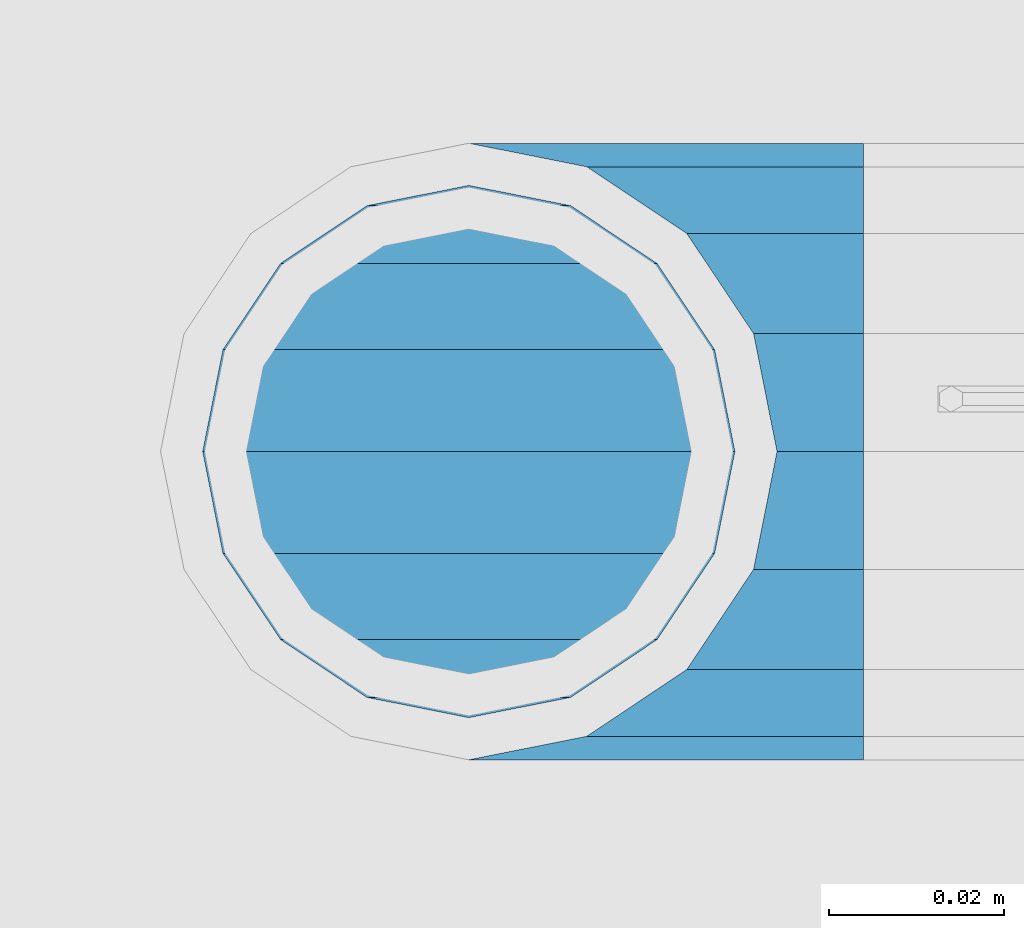
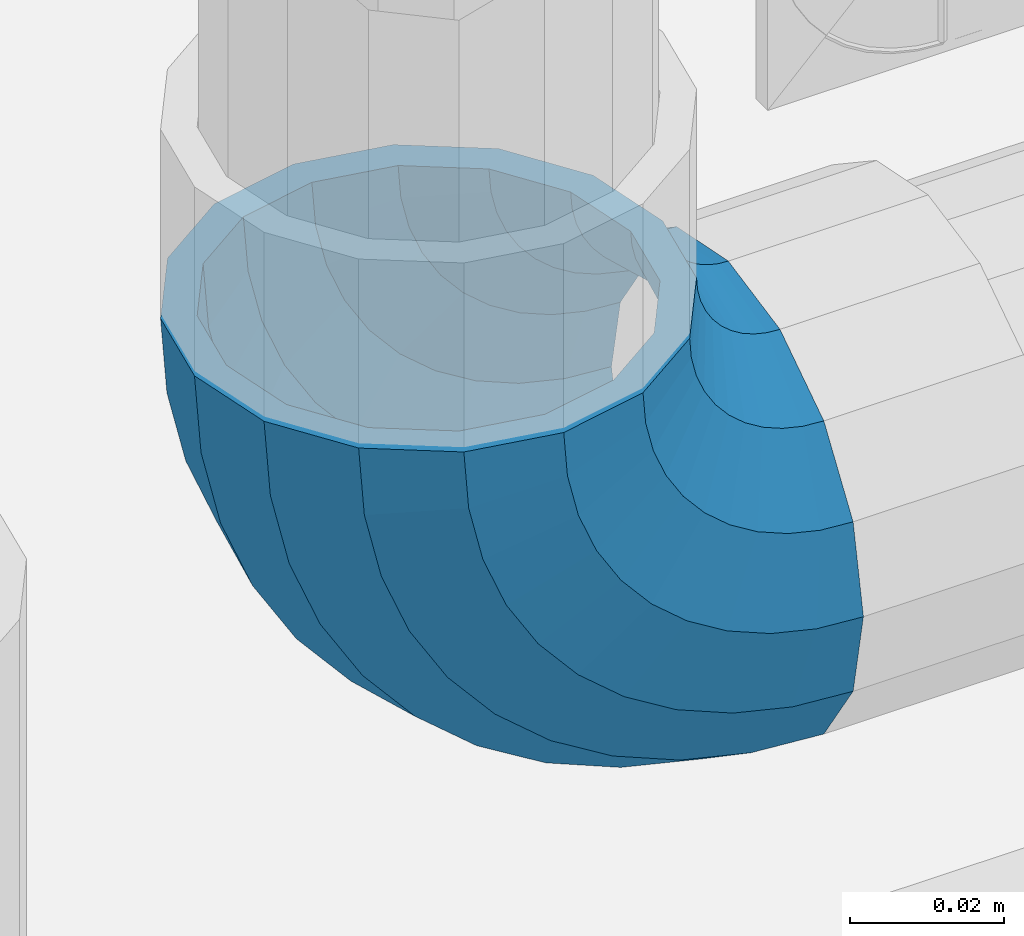
# One storey, part 136 of 208: 1 member.
"""IFC2X3 building model written with IfcOpenShell, lengths in millimetres."""

from ifc_helpers import new_model, si_unit, frame, origin_with_axes, place, context, subcontext, project, spatial, faceted_brep, material, type_object, element, save


model = new_model("IFC2X3")

# Units and contexts
model_context = context("Model", 3, precision=1e-05, world=origin_with_axes())
body_context = subcontext(model_context, "Body", "Model", "MODEL_VIEW")
ifc_project = project(units=[si_unit("LENGTHUNIT", "METRE", prefix="MILLI"), si_unit("AREAUNIT", "SQUARE_METRE"), si_unit("VOLUMEUNIT", "CUBIC_METRE"), si_unit("MASSUNIT", "GRAM", prefix="KILO"), si_unit("TIMEUNIT", "SECOND"), si_unit("PLANEANGLEUNIT", "RADIAN"), si_unit("SOLIDANGLEUNIT", "STERADIAN"), si_unit("THERMODYNAMICTEMPERATUREUNIT", "DEGREE_CELSIUS"), si_unit("LUMINOUSINTENSITYUNIT", "LUMEN")], contexts=[model_context])

# Site, building, storey
site_placement = place(None, origin_with_axes())
site = spatial("IfcSite", under=ifc_project, at=site_placement, CompositionType="ELEMENT")
building_placement = place(site_placement, origin_with_axes())
building = spatial("IfcBuilding", under=site, at=building_placement, Name="Standard", CompositionType="ELEMENT")
storey_placement = place(building_placement, origin_with_axes())
storey = spatial("IfcBuildingStorey", under=building, at=storey_placement, Name="Undefined", CompositionType="ELEMENT", Elevation=0.0)

# Member
ifc_material = material(Name="Misc_Undefined")
member_type = type_object("IfcMemberType", PredefinedType="NOTDEFINED")
member_placement = place(storey_placement, frame((-27328.39, 4664.5, 343.170000000002), z_axis=(-0.707106781186548, 0.0, -0.707106781186548), x_axis=(0.707106781186548, 0.0, -0.707106781186548)))
element("IfcMember", 1, at=member_placement, inside=storey, type_object=member_type, material=ifc_material, context=body_context, shape_type="Brep", body=[
    faceted_brep([(0.0, -35.1499999999996, 0.0), (9.51152146007371, -32.4743655677721, -9.51152146006643), (13.2759578763435, -32.4743655677721, -6.29638902527222), (5.3694688002397, -35.1499999999996, 4.58595959348168), (17.5750000000044, -24.8548033587067, -17.5749999999971), (19.9787556631163, -24.8548033587067, -15.5219987155615), (22.9628441077075, -13.4513226476329, -22.9628441076966), (24.4574219585302, -13.4513226476329, -21.6863540323902), (24.854803358714, 0.0, -24.8548033587031), (26.0301204183197, 0.0, -23.8509877588003), (22.9628441077075, 13.4513226476329, -22.9628441076966), (24.4574219585302, 13.4513226476329, -21.6863540323902), (17.5750000000044, 24.8548033587067, -17.5749999999971), (19.9787556631163, 24.8548033587067, -15.5219987155615), (9.51152146007371, 32.4743655677721, -9.51152146006643), (13.2759578763435, 32.4743655677721, -6.29638902527222), (0.0, 35.1499999999996, 0.0), (5.3694688002397, 35.1499999999996, 4.58595959348168), (-9.51152146006643, 32.4743655677721, 9.51152146007371), (-2.53702027587133, 32.4743655677721, 15.4683082122356), (-17.5749999999935, 24.8548033587067, 17.5750000000044), (-9.23981806264055, 24.8548033587067, 24.6939179025248), (-22.9628441076966, 13.4513226476329, 22.9628441077039), (-13.7184843580508, 13.4513226476329, 30.8582732193536), (-24.8548033587031, 0.0, 24.854803358714), (-15.2911828178439, 0.0, 33.02290694576), (-22.9628441076966, -13.4513226476329, 22.9628441077039), (-13.7184843580508, -13.4513226476329, 30.8582732193536), (-17.5749999999935, -24.8548033587067, 17.5750000000044), (-9.23981806264055, -24.8548033587067, 24.6939179025248), (-9.51152146006643, -32.4743655677721, 9.51152146007371), (-2.53702027587133, -32.4743655677721, 15.4683082122356), (0.0, -30.3500000000004, 0.0), (-8.21265081971433, -28.0397438117179, 8.21265081972524), (-1.45732902223244, -28.0397438117179, 13.9822406910389), (5.3694688002397, -30.3500000000004, 4.58595959348168), (-15.1749999999956, -21.4606908090118, 15.1750000000029), (-7.24480876130838, -21.4606908090118, 21.9480231689995), (-19.8270929919963, -11.6144421722802, 19.8270929920036), (-11.1118790903529, -11.6144421722802, 27.2705888550809), (-21.4606908090063, 0.0, 21.4606908090136), (-12.46981360684, 0.0, 29.139625372758), (-19.8270929919963, 11.6144421722802, 19.8270929920036), (-11.1118790903529, 11.6144421722802, 27.2705888550809), (-15.1749999999956, 21.4606908090118, 15.1750000000029), (-7.24480876130838, 21.4606908090118, 21.9480231689995), (-8.21265081971433, 28.0397438117179, 8.21265081972524), (-1.45732902223244, 28.0397438117179, 13.9822406910389), (0.0, 30.3500000000004, 0.0), (5.3694688002397, 30.3500000000004, 4.58595959348168), (8.21265081972524, 28.0397438117179, -8.21265081971433), (12.1962666227082, 28.0397438117179, -4.81032150407918), (15.1750000000029, 21.4606908090118, -15.1749999999956), (17.9837463617841, 21.4606908090118, -12.7761039820325), (19.8270929920036, 11.6144421722802, -19.8270929919963), (21.850816690825, 11.6144421722802, -18.0986696681175), (21.4606908090136, 0.0, -21.4606908090063), (23.2087512073158, 0.0, -19.9677061857983), (19.8270929920036, -11.6144421722802, -19.8270929919963), (21.850816690825, -11.6144421722802, -18.0986696681175), (15.1750000000029, -21.4606908090118, -15.1749999999956), (17.9837463617841, -21.4606908090118, -12.7761039820325), (8.21265081972524, -28.0397438117179, -8.21265081971433), (12.1962666227082, -28.0397438117179, -4.81032150407918), (17.4970053560755, -32.4743655677721, -3.70972780291777), (11.3902326651187, -35.1499999999996, 8.27548843508339), (22.6740772628655, -24.8548033587067, -13.870303514941), (26.1332861179544, -13.4513226476329, -20.6593831546779), (27.3479987309656, 0.0, -23.0433908901359), (26.1332861179544, 13.4513226476329, -20.6593831546779), (22.6740772628655, 24.8548033587067, -13.870303514941), (17.4970053560755, 32.4743655677721, -3.70972780291777), (11.3902326651187, 35.1499999999996, 8.27548843508339), (5.28345997416181, 32.4743655677721, 20.2607046730918), (0.106388067368243, 24.8548033587067, 30.4212803851115), (-3.3528207877207, 13.4513226476329, 37.2103600248483), (-4.56753340072828, 0.0, 39.59436776031), (-3.3528207877207, -13.4513226476329, 37.2103600248483), (0.106388067368243, -24.8548033587067, 30.4212803851115), (5.28345997416181, -32.4743655677721, 20.2607046730918), (6.11738625912767, -28.0397438117179, 18.6240321853948), (11.3902326651187, -30.3500000000004, 8.27548843508339), (1.64728291998108, -21.4606908090118, 27.3971039595053), (-1.33954464053022, -11.6144421722802, 33.2590831078996), (-2.38837900197541, 0.0, 35.3175364441995), (-1.33954464053022, 11.6144421722802, 33.2590831078996), (1.64728291998108, 21.4606908090118, 27.3971039595053), (6.11738625912767, 28.0397438117179, 18.6240321853948), (11.3902326651187, 30.3500000000004, 8.27548843508339), (16.663079071106, 28.0397438117179, -2.07305531522434), (21.1331824102563, 21.4606908090118, -10.8461270893349), (24.1200099707712, 11.6144421722802, -16.7081062377256), (25.1688443322128, 0.0, -18.7665595740327), (24.1200099707712, -11.6144421722802, -16.7081062377256), (21.1331824102563, -21.4606908090118, -10.8461270893349), (16.663079071106, -28.0397438117179, -2.07305531522434), (22.0707277014626, -32.4743655677721, -1.81522997692809), (17.9140404065256, -35.1499999999996, 10.9777380798914), (25.5945970362154, -24.8548033587067, -12.6605846156417), (27.9491712485142, -13.4513226476329, -19.9072189058897), (28.7759877588032, 0.0, -22.4518984678834), (27.9491712485142, 13.4513226476329, -19.9072189058897), (25.5945970362154, 24.8548033587067, -12.6605846156417), (22.0707277014626, 32.4743655677721, -1.81522997692809), (17.9140404065256, 35.1499999999996, 10.9777380798914), (13.7573531115886, 32.4743655677721, 23.7707061367109), (10.2334837768358, 24.8548033587067, 34.6160607754246), (7.87890956454066, 13.4513226476329, 41.8626950656726), (7.05209305424796, 0.0, 44.4073746276663), (7.87890956454066, -13.4513226476329, 41.8626950656726), (10.2334837768358, -24.8548033587067, 34.6160607754246), (13.7573531115886, -32.4743655677721, 23.7707061367109), (14.3249803951076, -28.0397438117179, 22.023728990971), (17.9140404065256, -30.3500000000004, 10.9777380798914), (11.2823222355146, -21.4606908090118, 31.3880679180002), (9.2492830507872, -11.6144421722802, 37.6451191472734), (8.53537462724489, 0.0, 39.8423033494473), (9.2492830507872, 11.6144421722802, 37.6451191472734), (11.2823222355146, 21.4606908090118, 31.3880679180002), (14.3249803951076, 28.0397438117179, 22.023728990971), (17.9140404065256, 30.3500000000004, 10.9777380798914), (21.5031004179436, 28.0397438117179, -0.0682528311917849), (24.5457585775366, 21.4606908090118, -9.43259175821368), (26.5787977622676, 11.6144421722802, -15.6896429874905), (27.2927061858063, 0.0, -17.8868271896645), (26.5787977622676, -11.6144421722802, -15.6896429874905), (24.5457585775366, -21.4606908090118, -9.43259175821368), (21.5031004179436, -28.0397438117179, -0.0682528311917849), (26.8845046890528, -32.4743655677721, -0.659544371261291), (24.7802542265854, -35.1499999999996, 12.6261701733893), (28.6684020936882, -24.8548033587067, -11.9226293117899), (29.860364231703, -13.4513226476329, -19.4483820661189), (30.2789256727519, 0.0, -22.0910749985305), (29.860364231703, 13.4513226476329, -19.4483820661189), (28.6684020936882, 24.8548033587067, -11.9226293117899), (26.8845046890528, 32.4743655677721, -0.659544371261291), (24.7802542265854, 35.1499999999996, 12.6261701733893), (22.6760037641179, 32.4743655677721, 25.9118847180434), (20.8921063594898, 24.8548033587067, 37.1749696585721), (19.7001442214714, 13.4513226476329, 44.7007224129011), (19.2815827804225, 0.0, 47.343415345309), (19.7001442214714, -13.4513226476329, 44.7007224129011), (20.8921063594898, -24.8548033587067, 37.1749696585721), (22.6760037641179, -32.4743655677721, 25.9118847180434), (22.9633551786246, -28.0397438117179, 24.0976192894668), (24.7802542265854, -30.3500000000004, 12.6261701733893), (21.4230625404853, -21.4606908090118, 33.8226442665691), (20.3938719035395, -11.6144421722802, 40.3206982094998), (20.0324682126193, 0.0, 42.6025113104552), (20.3938719035395, 11.6144421722802, 40.3206982094998), (21.4230625404853, 21.4606908090118, 33.8226442665691), (22.9633551786246, 28.0397438117179, 24.0976192894668), (24.7802542265854, 30.3500000000004, 12.6261701733893), (26.5971532745498, 28.0397438117179, 1.15472105731169), (28.1374459126891, 21.4606908090118, -8.5703039197906), (29.1666365496385, 11.6144421722802, -15.0683578627177), (29.5280402405588, 0.0, -17.350170963673), (29.1666365496385, -11.6144421722802, -15.0683578627177), (28.1374459126891, -21.4606908090118, -8.5703039197906), (26.5971532745498, -28.0397438117179, 1.15472105731169), (31.8198051533982, -32.4743655677721, -0.271127801024704), (31.8198051533982, -35.1499999999996, 13.1801948466091), (31.8198051533982, -24.8548033587067, -11.6746085120976), (31.8198051533982, -13.4513226476329, -19.2941707211648), (31.8198051533982, 0.0, -21.9698051533924), (31.8198051533982, 13.4513226476329, -19.2941707211648), (31.8198051533982, 24.8548033587067, -11.6746085120976), (31.8198051533982, 32.4743655677721, -0.271127801024704), (31.8198051533982, 35.1499999999996, 13.1801948466091), (31.8198051533982, 32.4743655677721, 26.6315174942429), (31.8198051533982, 24.8548033587067, 38.0349982053158), (31.8198051533946, 13.4513226476329, 45.654560414383), (31.8198051534018, 0.0, 48.3301948466105), (31.8198051533946, -13.4513226476329, 45.654560414383), (31.8198051533982, -24.8548033587067, 38.0349982053158), (31.8198051533982, -32.4743655677721, 26.6315174942429), (31.8198051533982, -28.0397438117179, 24.7946370188874), (31.8198051533982, -30.3500000000004, 13.1801948466091), (31.8198051533982, -21.4606908090118, 34.6408856556227), (31.8198051533982, -11.6144421722802, 41.219938658327), (31.8198051533982, 0.0, 43.5301948466113), (31.8198051533982, 11.6144421722802, 41.219938658327), (31.8198051533982, 21.4606908090118, 34.6408856556227), (31.8198051533982, 28.0397438117179, 24.7946370188874), (31.8198051533982, 30.3500000000004, 13.1801948466091), (31.8198051533946, 28.0397438117179, 1.56575267433072), (31.8198051533982, 21.4606908090118, -8.28049596240453), (31.8198051533982, 11.6144421722802, -14.8595489651088), (31.8198051533982, 0.0, -17.1698051533895), (31.8198051533982, -11.6144421722802, -14.8595489651088), (31.8198051533982, -21.4606908090118, -8.28049596240453), (31.8198051533946, -28.0397438117179, 1.56575267433072), (36.7551056177435, -32.4743655677721, -0.659544371261291), (38.859356080211, -35.1499999999996, 12.6261701733929), (34.9712082131082, -24.8548033587067, -11.9226293117899), (33.7792460750898, -13.4513226476329, -19.4483820661189), (33.3606846340444, 0.0, -22.0910749985269), (33.7792460750898, 13.4513226476329, -19.4483820661189), (34.9712082131082, 24.8548033587067, -11.9226293117899), (36.7551056177435, 32.4743655677721, -0.659544371261291), (38.859356080211, 35.1499999999996, 12.6261701733929), (40.9636065426712, 32.4743655677721, 25.9118847180434), (42.7475039473065, 24.8548033587067, 37.1749696585684), (43.939466085325, 13.4513226476329, 44.7007224129047), (44.3580275263703, 0.0, 47.343415345309), (43.939466085325, -13.4513226476329, 44.7007224129047), (42.7475039473065, -24.8548033587067, 37.1749696585684), (40.9636065426712, -32.4743655677721, 25.9118847180434), (40.6762551281718, -28.0397438117179, 24.0976192894668), (38.859356080211, -30.3500000000004, 12.6261701733929), (42.2165477663111, -21.4606908090118, 33.8226442665691), (43.2457384032568, -11.6144421722802, 40.3206982094998), (43.6071420941771, 0.0, 42.6025113104515), (43.2457384032568, 11.6144421722802, 40.3206982094998), (42.2165477663111, 21.4606908090118, 33.8226442665691), (40.6762551281718, 28.0397438117179, 24.0976192894668), (38.859356080211, 30.3500000000004, 12.6261701733929), (37.0424570322466, 28.0397438117179, 1.15472105731169), (35.5021643941072, 21.4606908090118, -8.5703039197906), (34.4729737571579, 11.6144421722802, -15.0683578627177), (34.1115700662376, 0.0, -17.350170963673), (34.4729737571579, -11.6144421722802, -15.0683578627177), (35.5021643941072, -21.4606908090118, -8.5703039197906), (37.0424570322466, -28.0397438117179, 1.15472105731169), (41.5688826053338, -32.4743655677721, -1.81522997692809), (45.7255699002708, -35.1499999999996, 10.9777380798914), (38.045013270581, -24.8548033587067, -12.6605846156417), (35.6904390582822, -13.4513226476329, -19.9072189058897), (34.8636225479895, 0.0, -22.4518984678834), (35.6904390582822, 13.4513226476329, -19.9072189058897), (38.045013270581, 24.8548033587067, -12.6605846156417), (41.5688826053338, 32.4743655677721, -1.81522997692809), (45.7255699002708, 35.1499999999996, 10.9777380798914), (49.8822571952114, 32.4743655677721, 23.7707061367109), (53.4061265299606, 24.8548033587067, 34.6160607754246), (55.7607007422557, 13.4513226476329, 41.8626950656726), (56.5875172525484, 0.0, 44.4073746276699), (55.7607007422557, -13.4513226476329, 41.8626950656726), (53.4061265299606, -24.8548033587067, 34.6160607754246), (49.8822571952114, -32.4743655677721, 23.7707061367109), (49.3146299116925, -28.0397438117179, 22.0237289909746), (45.7255699002708, -30.3500000000004, 10.9777380798914), (52.3572880712818, -21.4606908090118, 31.3880679179965), (54.3903272560092, -11.6144421722802, 37.6451191472697), (55.1042356795515, 0.0, 39.8423033494473), (54.3903272560092, 11.6144421722802, 37.6451191472697), (52.3572880712818, 21.4606908090118, 31.3880679179965), (49.3146299116925, 28.0397438117179, 22.0237289909746), (45.7255699002708, 30.3500000000004, 10.9777380798914), (42.1365098888527, 28.0397438117179, -0.0682528311917849), (39.0938517292598, 21.4606908090118, -9.43259175821368), (37.0608125445287, 11.6144421722802, -15.6896429874905), (36.3469041209937, 0.0, -17.8868271896645), (37.0608125445287, -11.6144421722802, -15.6896429874905), (39.0938517292598, -21.4606908090118, -9.43259175821368), (42.1365098888527, -28.0397438117179, -0.0682528311917849), (46.1426049507245, -32.4743655677721, -3.70972780291777), (52.2493776416777, -35.1499999999996, 8.27548843508339), (40.9655330439309, -24.8548033587067, -13.870303514941), (37.506324188842, -13.4513226476329, -20.6593831546743), (36.2916115758308, 0.0, -23.0433908901359), (37.506324188842, 13.4513226476329, -20.6593831546743), (40.9655330439309, 24.8548033587067, -13.870303514941), (46.1426049507245, 32.4743655677721, -3.70972780291777), (52.2493776416777, 35.1499999999996, 8.27548843508339), (58.3561503326309, 32.4743655677721, 20.2607046730918), (63.5332222394245, 24.8548033587067, 30.4212803851151), (66.9924310945171, 13.4513226476329, 37.2103600248483), (68.207143707521, 0.0, 39.5943677603063), (66.9924310945171, -13.4513226476329, 37.2103600248483), (63.5332222394245, -24.8548033587067, 30.4212803851151), (58.3561503326309, -32.4743655677721, 20.2607046730918), (57.5222240476687, -28.0397438117179, 18.6240321853984), (52.2493776416777, -30.3500000000004, 8.27548843508339), (61.9923273868153, -21.4606908090118, 27.3971039595053), (64.9791549473266, -11.6144421722802, 33.259083107896), (66.0279893087718, 0.0, 35.3175364442068), (64.9791549473266, 11.6144421722802, 33.259083107896), (61.9923273868153, 21.4606908090118, 27.3971039595053), (57.5222240476687, 28.0397438117179, 18.6240321853984), (52.2493776416777, 30.3500000000004, 8.27548843508339), (46.9765312356867, 28.0397438117179, -2.0730553152207), (42.5064278965401, 21.4606908090118, -10.8461270893349), (39.5196003360288, 11.6144421722802, -16.7081062377256), (38.4707659745836, 0.0, -18.7665595740327), (39.5196003360288, -11.6144421722802, -16.7081062377256), (42.5064278965401, -21.4606908090118, -10.8461270893349), (46.9765312356867, -28.0397438117179, -2.0730553152207), (50.3636524304529, -32.4743655677721, -6.29638902527222), (58.2701415065603, -35.1499999999996, 4.58595959348168), (43.6608546436801, -24.8548033587067, -15.5219987155615), (39.1821883482698, -13.4513226476329, -21.6863540323902), (37.6094898884767, 0.0, -23.8509877587967), (39.1821883482698, 13.4513226476329, -21.6863540323902), (43.6608546436801, 24.8548033587067, -15.5219987155615), (50.3636524304529, 32.4743655677721, -6.29638902527222), (58.2701415065603, 35.1499999999996, 4.58595959348168), (66.1766305826677, 32.4743655677721, 15.4683082122392), (72.8794283694369, 24.8548033587067, 24.6939179025212), (77.3580946648508, 13.4513226476329, 30.8582732193536), (78.9307931246403, 0.0, 33.02290694576), (77.3580946648508, -13.4513226476329, 30.8582732193536), (72.8794283694369, -24.8548033587067, 24.6939179025212), (66.1766305826677, -32.4743655677721, 15.4683082122392), (65.0969393290288, -28.0397438117179, 13.9822406910425), (58.2701415065603, -30.3500000000004, 4.58595959348168), (70.8844190681048, -21.4606908090118, 21.9480231689995), (74.7514893971456, -11.6144421722802, 27.2705888550845), (76.1094239136364, 0.0, 29.1396253727617), (74.7514893971456, 11.6144421722802, 27.2705888550845), (70.8844190681048, 21.4606908090118, 21.9480231689995), (65.0969393290288, 28.0397438117179, 13.9822406910425), (58.2701415065603, 30.3500000000004, 4.58595959348168), (51.4433436840882, 28.0397438117179, -4.81032150407918), (45.6558639450122, 21.4606908090118, -12.7761039820361), (41.7887936159714, 11.6144421722802, -18.0986696681175), (40.4308590994842, 0.0, -19.9677061857983), (41.7887936159714, -11.6144421722802, -18.0986696681175), (45.6558639450122, -21.4606908090118, -12.7761039820361), (51.4433436840882, -28.0397438117179, -4.81032150407918), (54.1280888467227, -32.4743655677721, -9.51152146006643), (63.6396103067927, -35.1499999999996, 3.63797880709171e-12), (46.064610306792, -24.8548033587067, -17.5749999999971), (40.6767661990889, -13.4513226476329, -22.9628441077002), (38.784806948086, 0.0, -24.8548033587031), (40.6767661990889, 13.4513226476329, -22.9628441077002), (46.064610306792, 24.8548033587067, -17.5749999999971), (54.1280888467227, 32.4743655677721, -9.51152146006643), (63.6396103067927, 35.1499999999996, 3.63797880709171e-12), (73.1511317668628, 32.4743655677721, 9.51152146007371), (81.2146103067935, 24.8548033587067, 17.5750000000044), (86.602454414493, 13.4513226476329, 22.9628441077075), (88.4944136654995, 0.0, 24.8548033587103), (86.602454414493, -13.4513226476329, 22.9628441077075), (81.2146103067935, -24.8548033587067, 17.5750000000044), (73.1511317668628, -32.4743655677721, 9.51152146007371), (71.8522611265107, -28.0397438117179, 8.2126508197216), (63.6396103067927, -30.3500000000004, 3.63797880709171e-12), (78.814610306792, -21.4606908090118, 15.1750000000029), (83.4667032987927, -11.6144421722802, 19.8270929920036), (85.1003011158027, 0.0, 21.4606908090136), (83.4667032987927, 11.6144421722802, 19.8270929920036), (78.814610306792, 21.4606908090118, 15.1750000000029), (71.8522611265107, 28.0397438117179, 8.2126508197216), (63.6396103067927, 30.3500000000004, 3.63797880709171e-12), (55.4269594870748, 28.0397438117179, -8.21265081971433), (48.4646103067935, 21.4606908090118, -15.1749999999956), (43.8125173147928, 11.6144421722802, -19.8270929919963), (42.1789194977791, 0.0, -21.4606908090063), (43.8125173147928, -11.6144421722802, -19.8270929919963), (48.4646103067935, -21.4606908090118, -15.1749999999956), (55.4269594870748, -28.0397438117179, -8.21265081971433)], [[[0, 1, 2, 3]], [[1, 4, 5, 2]], [[4, 6, 7, 5]], [[6, 8, 9, 7]], [[8, 10, 11, 9]], [[10, 12, 13, 11]], [[12, 14, 15, 13]], [[14, 16, 17, 15]], [[16, 18, 19, 17]], [[18, 20, 21, 19]], [[20, 22, 23, 21]], [[22, 24, 25, 23]], [[24, 26, 27, 25]], [[26, 28, 29, 27]], [[28, 30, 31, 29]], [[30, 0, 3, 31]], [[32, 33, 34, 35]], [[33, 36, 37, 34]], [[36, 38, 39, 37]], [[38, 40, 41, 39]], [[40, 42, 43, 41]], [[42, 44, 45, 43]], [[44, 46, 47, 45]], [[46, 48, 49, 47]], [[48, 50, 51, 49]], [[50, 52, 53, 51]], [[52, 54, 55, 53]], [[54, 56, 57, 55]], [[56, 58, 59, 57]], [[58, 60, 61, 59]], [[60, 62, 63, 61]], [[62, 32, 35, 63]], [[30, 28, 26, 24, 22, 20, 18, 16, 14, 12, 10, 8, 6, 4, 1, 0], [62, 60, 58, 56, 54, 52, 50, 48, 46, 44, 42, 40, 38, 36, 33, 32]], [[3, 2, 64, 65]], [[2, 5, 66, 64]], [[5, 7, 67, 66]], [[7, 9, 68, 67]], [[9, 11, 69, 68]], [[11, 13, 70, 69]], [[13, 15, 71, 70]], [[15, 17, 72, 71]], [[17, 19, 73, 72]], [[19, 21, 74, 73]], [[21, 23, 75, 74]], [[23, 25, 76, 75]], [[25, 27, 77, 76]], [[27, 29, 78, 77]], [[29, 31, 79, 78]], [[31, 3, 65, 79]], [[35, 34, 80, 81]], [[34, 37, 82, 80]], [[37, 39, 83, 82]], [[39, 41, 84, 83]], [[41, 43, 85, 84]], [[43, 45, 86, 85]], [[45, 47, 87, 86]], [[47, 49, 88, 87]], [[49, 51, 89, 88]], [[51, 53, 90, 89]], [[53, 55, 91, 90]], [[55, 57, 92, 91]], [[57, 59, 93, 92]], [[59, 61, 94, 93]], [[61, 63, 95, 94]], [[63, 35, 81, 95]], [[65, 64, 96, 97]], [[64, 66, 98, 96]], [[66, 67, 99, 98]], [[67, 68, 100, 99]], [[68, 69, 101, 100]], [[69, 70, 102, 101]], [[70, 71, 103, 102]], [[71, 72, 104, 103]], [[72, 73, 105, 104]], [[73, 74, 106, 105]], [[74, 75, 107, 106]], [[75, 76, 108, 107]], [[76, 77, 109, 108]], [[77, 78, 110, 109]], [[78, 79, 111, 110]], [[79, 65, 97, 111]], [[81, 80, 112, 113]], [[80, 82, 114, 112]], [[82, 83, 115, 114]], [[83, 84, 116, 115]], [[84, 85, 117, 116]], [[85, 86, 118, 117]], [[86, 87, 119, 118]], [[87, 88, 120, 119]], [[88, 89, 121, 120]], [[89, 90, 122, 121]], [[90, 91, 123, 122]], [[91, 92, 124, 123]], [[92, 93, 125, 124]], [[93, 94, 126, 125]], [[94, 95, 127, 126]], [[95, 81, 113, 127]], [[97, 96, 128, 129]], [[96, 98, 130, 128]], [[98, 99, 131, 130]], [[99, 100, 132, 131]], [[100, 101, 133, 132]], [[101, 102, 134, 133]], [[102, 103, 135, 134]], [[103, 104, 136, 135]], [[104, 105, 137, 136]], [[105, 106, 138, 137]], [[106, 107, 139, 138]], [[107, 108, 140, 139]], [[108, 109, 141, 140]], [[109, 110, 142, 141]], [[110, 111, 143, 142]], [[111, 97, 129, 143]], [[113, 112, 144, 145]], [[112, 114, 146, 144]], [[114, 115, 147, 146]], [[115, 116, 148, 147]], [[116, 117, 149, 148]], [[117, 118, 150, 149]], [[118, 119, 151, 150]], [[119, 120, 152, 151]], [[120, 121, 153, 152]], [[121, 122, 154, 153]], [[122, 123, 155, 154]], [[123, 124, 156, 155]], [[124, 125, 157, 156]], [[125, 126, 158, 157]], [[126, 127, 159, 158]], [[127, 113, 145, 159]], [[129, 128, 160, 161]], [[128, 130, 162, 160]], [[130, 131, 163, 162]], [[131, 132, 164, 163]], [[132, 133, 165, 164]], [[133, 134, 166, 165]], [[134, 135, 167, 166]], [[135, 136, 168, 167]], [[136, 137, 169, 168]], [[137, 138, 170, 169]], [[138, 139, 171, 170]], [[139, 140, 172, 171]], [[140, 141, 173, 172]], [[141, 142, 174, 173]], [[142, 143, 175, 174]], [[143, 129, 161, 175]], [[145, 144, 176, 177]], [[144, 146, 178, 176]], [[146, 147, 179, 178]], [[147, 148, 180, 179]], [[148, 149, 181, 180]], [[149, 150, 182, 181]], [[150, 151, 183, 182]], [[151, 152, 184, 183]], [[152, 153, 185, 184]], [[153, 154, 186, 185]], [[154, 155, 187, 186]], [[155, 156, 188, 187]], [[156, 157, 189, 188]], [[157, 158, 190, 189]], [[158, 159, 191, 190]], [[159, 145, 177, 191]], [[161, 160, 192, 193]], [[160, 162, 194, 192]], [[162, 163, 195, 194]], [[163, 164, 196, 195]], [[164, 165, 197, 196]], [[165, 166, 198, 197]], [[166, 167, 199, 198]], [[167, 168, 200, 199]], [[168, 169, 201, 200]], [[169, 170, 202, 201]], [[170, 171, 203, 202]], [[171, 172, 204, 203]], [[172, 173, 205, 204]], [[173, 174, 206, 205]], [[174, 175, 207, 206]], [[175, 161, 193, 207]], [[177, 176, 208, 209]], [[176, 178, 210, 208]], [[178, 179, 211, 210]], [[179, 180, 212, 211]], [[180, 181, 213, 212]], [[181, 182, 214, 213]], [[182, 183, 215, 214]], [[183, 184, 216, 215]], [[184, 185, 217, 216]], [[185, 186, 218, 217]], [[186, 187, 219, 218]], [[187, 188, 220, 219]], [[188, 189, 221, 220]], [[189, 190, 222, 221]], [[190, 191, 223, 222]], [[191, 177, 209, 223]], [[193, 192, 224, 225]], [[192, 194, 226, 224]], [[194, 195, 227, 226]], [[195, 196, 228, 227]], [[196, 197, 229, 228]], [[197, 198, 230, 229]], [[198, 199, 231, 230]], [[199, 200, 232, 231]], [[200, 201, 233, 232]], [[201, 202, 234, 233]], [[202, 203, 235, 234]], [[203, 204, 236, 235]], [[204, 205, 237, 236]], [[205, 206, 238, 237]], [[206, 207, 239, 238]], [[207, 193, 225, 239]], [[209, 208, 240, 241]], [[208, 210, 242, 240]], [[210, 211, 243, 242]], [[211, 212, 244, 243]], [[212, 213, 245, 244]], [[213, 214, 246, 245]], [[214, 215, 247, 246]], [[215, 216, 248, 247]], [[216, 217, 249, 248]], [[217, 218, 250, 249]], [[218, 219, 251, 250]], [[219, 220, 252, 251]], [[220, 221, 253, 252]], [[221, 222, 254, 253]], [[222, 223, 255, 254]], [[223, 209, 241, 255]], [[225, 224, 256, 257]], [[224, 226, 258, 256]], [[226, 227, 259, 258]], [[227, 228, 260, 259]], [[228, 229, 261, 260]], [[229, 230, 262, 261]], [[230, 231, 263, 262]], [[231, 232, 264, 263]], [[232, 233, 265, 264]], [[233, 234, 266, 265]], [[234, 235, 267, 266]], [[235, 236, 268, 267]], [[236, 237, 269, 268]], [[237, 238, 270, 269]], [[238, 239, 271, 270]], [[239, 225, 257, 271]], [[241, 240, 272, 273]], [[240, 242, 274, 272]], [[242, 243, 275, 274]], [[243, 244, 276, 275]], [[244, 245, 277, 276]], [[245, 246, 278, 277]], [[246, 247, 279, 278]], [[247, 248, 280, 279]], [[248, 249, 281, 280]], [[249, 250, 282, 281]], [[250, 251, 283, 282]], [[251, 252, 284, 283]], [[252, 253, 285, 284]], [[253, 254, 286, 285]], [[254, 255, 287, 286]], [[255, 241, 273, 287]], [[257, 256, 288, 289]], [[256, 258, 290, 288]], [[258, 259, 291, 290]], [[259, 260, 292, 291]], [[260, 261, 293, 292]], [[261, 262, 294, 293]], [[262, 263, 295, 294]], [[263, 264, 296, 295]], [[264, 265, 297, 296]], [[265, 266, 298, 297]], [[266, 267, 299, 298]], [[267, 268, 300, 299]], [[268, 269, 301, 300]], [[269, 270, 302, 301]], [[270, 271, 303, 302]], [[271, 257, 289, 303]], [[273, 272, 304, 305]], [[272, 274, 306, 304]], [[274, 275, 307, 306]], [[275, 276, 308, 307]], [[276, 277, 309, 308]], [[277, 278, 310, 309]], [[278, 279, 311, 310]], [[279, 280, 312, 311]], [[280, 281, 313, 312]], [[281, 282, 314, 313]], [[282, 283, 315, 314]], [[283, 284, 316, 315]], [[284, 285, 317, 316]], [[285, 286, 318, 317]], [[286, 287, 319, 318]], [[287, 273, 305, 319]], [[289, 288, 320, 321]], [[288, 290, 322, 320]], [[290, 291, 323, 322]], [[291, 292, 324, 323]], [[292, 293, 325, 324]], [[293, 294, 326, 325]], [[294, 295, 327, 326]], [[295, 296, 328, 327]], [[296, 297, 329, 328]], [[297, 298, 330, 329]], [[298, 299, 331, 330]], [[299, 300, 332, 331]], [[300, 301, 333, 332]], [[301, 302, 334, 333]], [[302, 303, 335, 334]], [[303, 289, 321, 335]], [[305, 304, 336, 337]], [[304, 306, 338, 336]], [[306, 307, 339, 338]], [[307, 308, 340, 339]], [[308, 309, 341, 340]], [[309, 310, 342, 341]], [[310, 311, 343, 342]], [[311, 312, 344, 343]], [[312, 313, 345, 344]], [[313, 314, 346, 345]], [[314, 315, 347, 346]], [[315, 316, 348, 347]], [[316, 317, 349, 348]], [[317, 318, 350, 349]], [[318, 319, 351, 350]], [[319, 305, 337, 351]], [[322, 323, 324, 325, 326, 327, 328, 329, 330, 331, 332, 333, 334, 335, 321, 320], [338, 339, 340, 341, 342, 343, 344, 345, 346, 347, 348, 349, 350, 351, 337, 336]]]),
])

save(model, "model.ifc")
